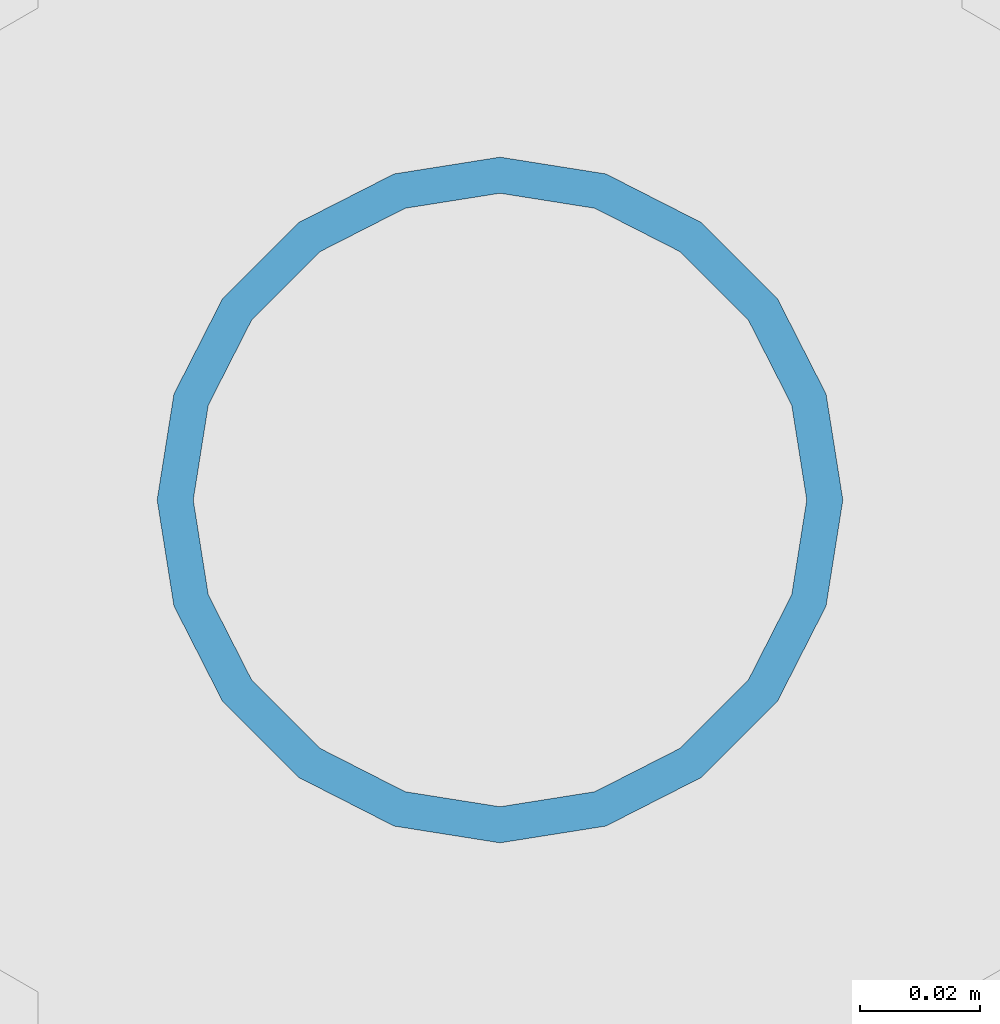
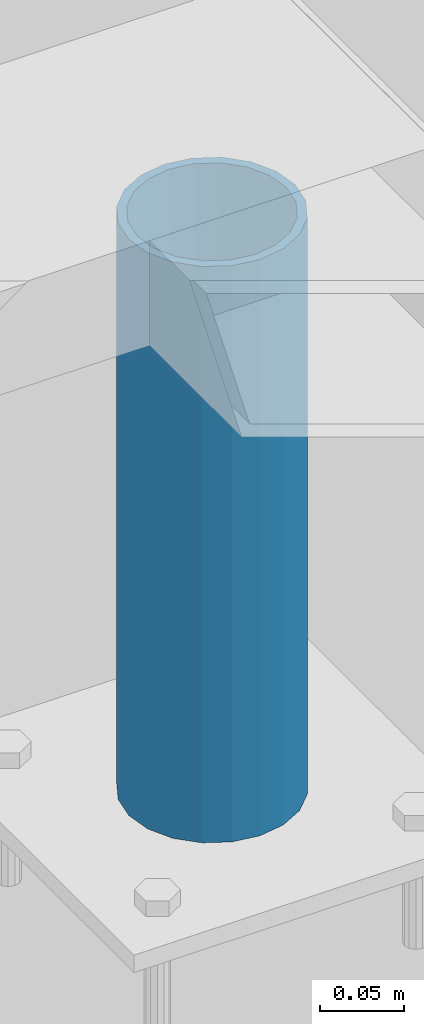
# One storey, part 549 of 1179: 1 column, 1 element without a shape of its own.
"""IFC2X3 building model written with IfcOpenShell, lengths in millimetres."""

from ifc_helpers import new_model, si_unit, frame, origin_with_axes, place, context, subcontext, project, spatial, faceted_brep, material, type_object, element, aggregate, save


model = new_model("IFC2X3")

# Units and contexts
model_context = context("Model", 3, precision=1e-05, world=origin_with_axes())
body_context = subcontext(model_context, "Body", "Model", "MODEL_VIEW")
ifc_project = project(units=[si_unit("LENGTHUNIT", "METRE", prefix="MILLI"), si_unit("AREAUNIT", "SQUARE_METRE"), si_unit("VOLUMEUNIT", "CUBIC_METRE"), si_unit("MASSUNIT", "GRAM", prefix="KILO"), si_unit("TIMEUNIT", "SECOND"), si_unit("PLANEANGLEUNIT", "RADIAN"), si_unit("SOLIDANGLEUNIT", "STERADIAN"), si_unit("THERMODYNAMICTEMPERATUREUNIT", "DEGREE_CELSIUS"), si_unit("LUMINOUSINTENSITYUNIT", "LUMEN")], contexts=[model_context])

# Site, building, storey
site_placement = place(None, origin_with_axes())
site = spatial("IfcSite", under=ifc_project, at=site_placement, CompositionType="ELEMENT")
building_placement = place(site_placement, origin_with_axes())
building = spatial("IfcBuilding", under=site, at=building_placement, Name="Undefined", CompositionType="ELEMENT")
storey_placement = place(building_placement, origin_with_axes())
storey = spatial("IfcBuildingStorey", under=building, at=storey_placement, Name="Undefined", CompositionType="ELEMENT", Elevation=0.0)

# Assembly, column
assembly_placement = place(storey_placement, origin_with_axes())
assembly = element("IfcElementAssembly", 1, at=assembly_placement, inside=storey, Name="FRAME", AssemblyPlace="NOTDEFINED", PredefinedType="RIGID_FRAME")
ifc_material = material()
column_type = type_object("IfcColumnType", Name="PIPE4SCH40", PredefinedType="NOTDEFINED")
column_placement = place(assembly_placement, frame((16738.6, 37528.5, 13265.15), z_axis=(0.0, 1.0, 0.0), x_axis=(0.0, 0.0, 1.0)))
column = element("IfcColumn", 2, at=column_placement, type_object=column_type, material=ifc_material, Name="COLUMN", ObjectType="PIPE4SCH40", context=body_context, shape_type="Brep", body=[
    faceted_brep([(0.0, -51.1301999999996, 0.0), (0.0, -48.6277098894752, 15.8001007257917), (419.099999999999, -48.6277098894752, 15.8001007257917), (419.099999999999, -51.1301999999996, 0.0), (0.0, -41.3652007257915, 30.0535775067619), (419.099999999999, -41.3652007257915, 30.0535775067619), (0.0, -30.0535775067656, 41.3652007257915), (419.099999999999, -30.0535775067656, 41.3652007257915), (0.0, -15.8001007257917, 48.6277098894716), (419.099999999999, -15.8001007257917, 48.6277098894716), (0.0, 0.0, 51.1301999999996), (419.099999999999, 0.0, 51.1301999999996), (0.0, 15.8001007257917, 48.6277098894716), (419.099999999999, 15.8001007257917, 48.6277098894716), (0.0, 30.0535775067656, 41.3652007257915), (419.099999999999, 30.0535775067656, 41.3652007257915), (0.0, 41.3652007257915, 30.0535775067619), (419.099999999999, 41.3652007257915, 30.0535775067619), (0.0, 48.6277098894752, 15.8001007257917), (419.099999999999, 48.6277098894752, 15.8001007257917), (0.0, 51.1301999999996, 0.0), (419.099999999999, 51.1301999999996, 0.0), (0.0, 48.6277098894752, -15.8001007257917), (419.099999999999, 48.6277098894752, -15.8001007257917), (0.0, 41.3652007257915, -30.0535775067619), (419.099999999999, 41.3652007257915, -30.0535775067619), (0.0, 30.0535775067656, -41.3652007257915), (419.099999999999, 30.0535775067656, -41.3652007257915), (0.0, 15.8001007257917, -48.6277098894716), (419.099999999999, 15.8001007257917, -48.6277098894716), (0.0, 0.0, -51.1301999999996), (419.099999999999, 0.0, -51.1301999999996), (0.0, -15.8001007257917, -48.6277098894716), (419.099999999999, -15.8001007257917, -48.6277098894716), (0.0, -30.0535775067656, -41.3652007257915), (419.099999999999, -30.0535775067656, -41.3652007257915), (0.0, -41.3652007257915, -30.0535775067619), (419.099999999999, -41.3652007257915, -30.0535775067619), (0.0, -48.6277098894752, -15.8001007257917), (419.099999999999, -48.6277098894752, -15.8001007257917), (0.0, -57.1500000000015, 0.0), (0.0, -54.3528799062697, -17.6603212285263), (419.099999999999, -54.3528799062697, -17.6603212285263), (419.099999999999, -57.1500000000015, 0.0), (0.0, -46.235321228527, -33.5919271685125), (419.099999999999, -46.235321228527, -33.5919271685125), (0.0, -33.5919271685161, -46.2353212285307), (419.099999999999, -33.5919271685161, -46.2353212285307), (0.0, -17.6603212285299, -54.3528799062697), (419.099999999999, -17.6603212285299, -54.3528799062697), (0.0, 0.0, -57.1500000000015), (419.099999999999, 0.0, -57.1500000000015), (0.0, 17.6603212285299, -54.3528799062697), (419.099999999999, 17.6603212285299, -54.3528799062697), (0.0, 33.5919271685161, -46.2353212285307), (419.099999999999, 33.5919271685161, -46.2353212285307), (0.0, 46.235321228527, -33.5919271685125), (419.099999999999, 46.235321228527, -33.5919271685125), (0.0, 54.3528799062697, -17.6603212285263), (419.099999999999, 54.3528799062697, -17.6603212285263), (0.0, 57.1500000000015, 0.0), (419.099999999999, 57.1500000000015, 0.0), (0.0, 54.3528799062697, 17.6603212285263), (419.099999999999, 54.3528799062697, 17.6603212285263), (0.0, 46.235321228527, 33.5919271685125), (419.099999999999, 46.235321228527, 33.5919271685125), (0.0, 33.5919271685161, 46.2353212285307), (419.099999999999, 33.5919271685161, 46.2353212285307), (0.0, 17.6603212285299, 54.3528799062697), (419.099999999999, 17.6603212285299, 54.3528799062697), (0.0, 0.0, 57.1500000000015), (419.099999999999, 0.0, 57.1500000000015), (0.0, -17.6603212285299, 54.3528799062697), (419.099999999999, -17.6603212285299, 54.3528799062697), (0.0, -33.5919271685161, 46.2353212285307), (419.099999999999, -33.5919271685161, 46.2353212285307), (0.0, -46.235321228527, 33.5919271685125), (419.099999999999, -46.235321228527, 33.5919271685125), (0.0, -54.3528799062697, 17.6603212285263), (419.099999999999, -54.3528799062697, 17.6603212285263)], [[[0, 1, 2, 3]], [[1, 4, 5, 2]], [[4, 6, 7, 5]], [[6, 8, 9, 7]], [[8, 10, 11, 9]], [[10, 12, 13, 11]], [[12, 14, 15, 13]], [[14, 16, 17, 15]], [[16, 18, 19, 17]], [[18, 20, 21, 19]], [[20, 22, 23, 21]], [[22, 24, 25, 23]], [[24, 26, 27, 25]], [[26, 28, 29, 27]], [[28, 30, 31, 29]], [[30, 32, 33, 31]], [[32, 34, 35, 33]], [[34, 36, 37, 35]], [[36, 38, 39, 37]], [[38, 0, 3, 39]], [[40, 41, 42, 43]], [[41, 44, 45, 42]], [[44, 46, 47, 45]], [[46, 48, 49, 47]], [[48, 50, 51, 49]], [[50, 52, 53, 51]], [[52, 54, 55, 53]], [[54, 56, 57, 55]], [[56, 58, 59, 57]], [[58, 60, 61, 59]], [[60, 62, 63, 61]], [[62, 64, 65, 63]], [[64, 66, 67, 65]], [[66, 68, 69, 67]], [[68, 70, 71, 69]], [[70, 72, 73, 71]], [[72, 74, 75, 73]], [[74, 76, 77, 75]], [[76, 78, 79, 77]], [[78, 40, 43, 79]], [[45, 47, 49, 51, 53, 55, 57, 59, 61, 63, 65, 67, 69, 71, 73, 75, 77, 79, 43, 42], [5, 7, 9, 11, 13, 15, 17, 19, 21, 23, 25, 27, 29, 31, 33, 35, 37, 39, 3, 2]], [[78, 76, 74, 72, 70, 68, 66, 64, 62, 60, 58, 56, 54, 52, 50, 48, 46, 44, 41, 40], [38, 36, 34, 32, 30, 28, 26, 24, 22, 20, 18, 16, 14, 12, 10, 8, 6, 4, 1, 0]]]),
])
aggregate(assembly, [column])

save(model, "model.ifc")
